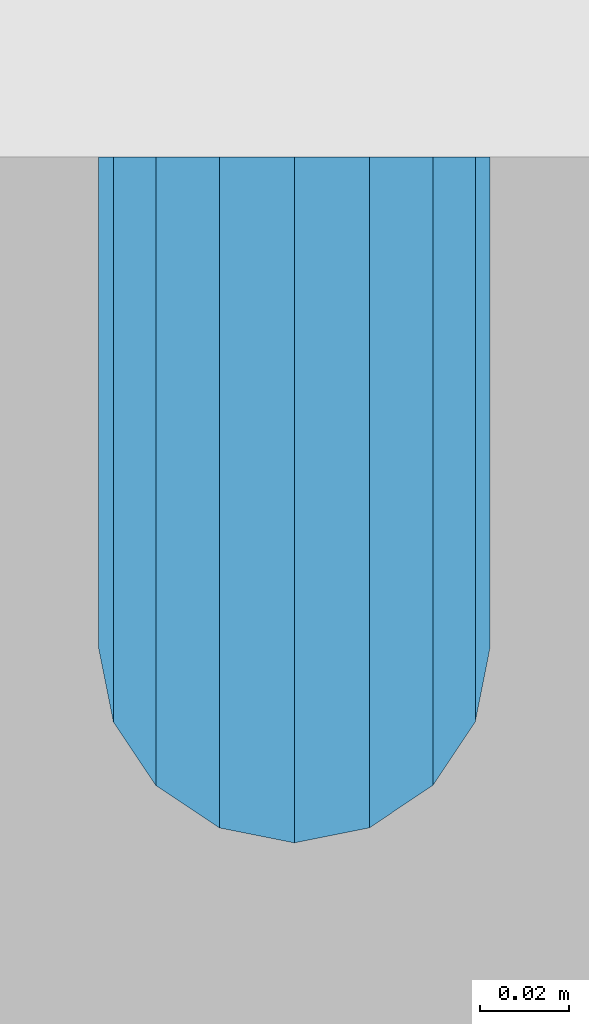
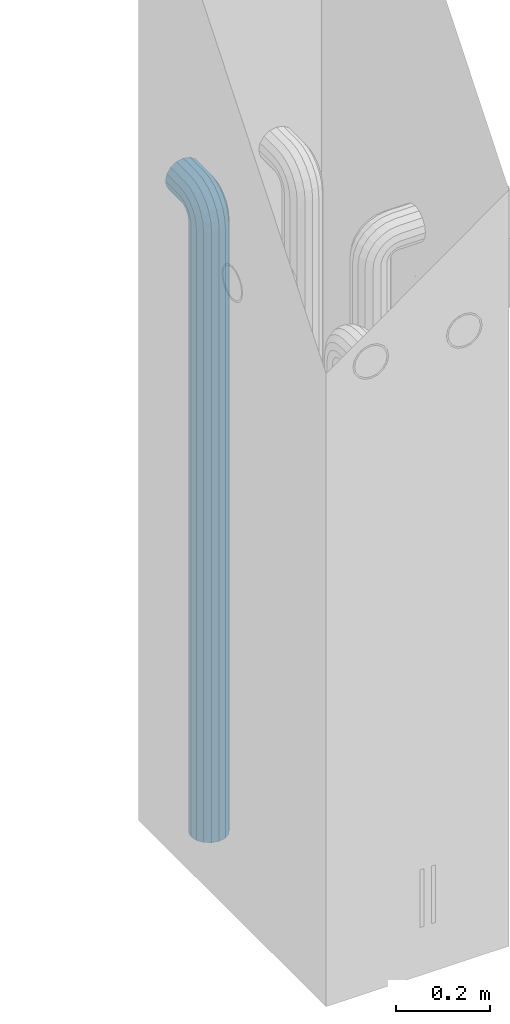
# One storey, part 3 of 41: 1 beam, 2 elements without a shape of their own.
"""IFC2X3 building model written with IfcOpenShell, lengths in millimetres."""

from ifc_helpers import new_model, si_unit, frame, origin_with_axes, place, context, subcontext, project, spatial, faceted_brep, material, type_object, element, aggregate, save


model = new_model("IFC2X3")

# Units and contexts
model_context = context("Model", 3, precision=1e-05, world=origin_with_axes())
body_context = subcontext(model_context, "Body", "Model", "MODEL_VIEW")
ifc_project = project(units=[si_unit("LENGTHUNIT", "METRE", prefix="MILLI"), si_unit("AREAUNIT", "SQUARE_METRE"), si_unit("VOLUMEUNIT", "CUBIC_METRE"), si_unit("MASSUNIT", "GRAM", prefix="KILO"), si_unit("TIMEUNIT", "SECOND"), si_unit("PLANEANGLEUNIT", "RADIAN"), si_unit("SOLIDANGLEUNIT", "STERADIAN"), si_unit("THERMODYNAMICTEMPERATUREUNIT", "DEGREE_CELSIUS"), si_unit("LUMINOUSINTENSITYUNIT", "LUMEN")], contexts=[model_context])

# Site, building, storey
site_placement = place(None, frame((-177556.685383467, -198018.589999756, 1290.0), z_axis=(0.0, 0.0, 1.0), x_axis=(0.788225611989142, -0.615386370180835, 0.0)))
site = spatial("IfcSite", under=ifc_project, at=site_placement, CompositionType="ELEMENT")
building_placement = place(site_placement, origin_with_axes())
building = spatial("IfcBuilding", under=site, at=building_placement, Name="Undefined", CompositionType="ELEMENT")
storey_placement = place(building_placement, origin_with_axes())
storey = spatial("IfcBuildingStorey", under=building, at=storey_placement, Name="Undefined", CompositionType="ELEMENT", Elevation=0.0)

# Assemblies, beam
assembly_1_placement = place(storey_placement, origin_with_axes())
assembly_1 = element("IfcElementAssembly", 1, at=assembly_1_placement, inside=storey, AssemblyPlace="NOTDEFINED", PredefinedType="REINFORCEMENT_UNIT")
assembly_2_placement = place(assembly_1_placement, origin_with_axes())
assembly_2 = element("IfcElementAssembly", 2, at=assembly_2_placement, AssemblyPlace="NOTDEFINED", PredefinedType="RIGID_FRAME")
aggregate(assembly_1, [assembly_2])
ifc_material = material(Name="STEEL/NEG_BETON")
beam_type = type_object("IfcBeamType", PredefinedType="NOTDEFINED")
beam_placement = place(assembly_2_placement, frame((17827.6776781408, 265507.104402164, -1290.0), z_axis=(0.615386370178831, -0.788225611990706, 0.0), x_axis=(0.0, 0.0, 1.0)))
beam = element("IfcBeam", 3, at=beam_placement, type_object=beam_type, material=ifc_material, context=body_context, shape_type="Brep", body=[
    faceted_brep([(0.0, -43.999999753345, 2.88331648334861e-07), (0.0, -40.6506991838105, -16.8380707357428), (1590.0, -40.6506991838105, -16.8380707357428), (1589.99999999999, -43.999999753345, 2.88331648334861e-07), (0.0, -31.1126981254783, -31.1126980838017), (1590.0, -31.1126981254783, -31.1126980838017), (0.0, -16.8380707773322, -40.6506991419883), (1590.0, -16.8380707773322, -40.6506991419883), (0.0, 2.46742274612188e-07, -43.9999997114064), (1590.0, 2.46742274612188e-07, -43.9999997114064), (0.0, 16.8380712707876, -40.6506991418137), (1590.0, 16.8380712707876, -40.6506991418137), (0.0, 31.1126986189047, -31.1126980834524), (1590.0, 31.1126986189047, -31.1126980834524), (0.0, 40.6506996771204, -16.8380707352771), (1590.0, 40.6506996771204, -16.8380707352771), (0.0, 44.0000002465677, 2.88768205791712e-07), (1590.0, 44.0000002465677, 2.88768205791712e-07), (0.0, 40.6506996770622, 16.8380713128427), (1590.0, 40.6506996770622, 16.8380713128427), (0.0, 31.1126986187301, 31.1126986609306), (1590.0, 31.1126986187301, 31.1126986609306), (0.0, 16.8380712705839, 40.6506997191464), (1590.0, 16.8380712705839, 40.6506997191464), (0.0, 2.46509443968534e-07, 44.0000002885354), (1590.0, 2.46509443968534e-07, 44.0000002885354), (0.0, -16.8380707775359, 40.6506997189426), (1590.0, -16.8380707775359, 40.6506997189426), (0.0, -31.1126981256821, 31.1126986605814), (1590.0, -31.1126981256821, 31.1126986605814), (0.0, -40.6506991838978, 16.838071312377), (1590.0, -40.6506991838978, 16.838071312377), (4.47878846898675e-07, -40.0000000634464, 0.0), (4.47878846898675e-07, -36.9551813638827, 15.3073372946019), (1590.0, -36.9551810538396, 15.3073375829845), (1589.99999999999, -39.999999753345, 2.88360752165318e-07), (4.47937054559588e-07, -28.2842713108694, 28.284271247463), (1590.0, -28.2842710008845, 28.2842715359002), (4.4800981413573e-07, -15.3073373580119, 36.9551813004509), (1590.0, -15.3073370480561, 36.9551815889135), (4.48068021796644e-07, -6.34463503956795e-08, 40.0), (1590.0, 2.46538547798991e-07, 40.0000002885645), (4.48140781372786e-07, 15.3073372311774, 36.9551813004509), (1590.0, 15.3073375411332, 36.9551815890882), (4.48213540948927e-07, 28.2842711840058, 28.284271247463), (1590.0, 28.2842714939907, 28.2842715361621), (4.48271748609841e-07, 36.95518123699, 15.3073372946019), (1590.0, 36.9551815469749, 15.3073375833046), (4.48286300525069e-07, 39.9999999365536, 0.0), (1590.0, 40.0000002465677, 2.88768205791712e-07), (4.48271748609841e-07, 36.95518123699, -15.3073372946019), (1590.0, 36.9551815470913, -15.3073370058555), (4.48213540948927e-07, 28.2842711840058, -28.284271247463), (1590.0, 28.2842714941071, -28.2842709587712), (4.48140781372786e-07, 15.3073372311774, -36.9551813004509), (1590.0, 15.3073375413369, -36.9551810117846), (4.48068021796644e-07, -6.34463503956795e-08, -40.0), (1590.0, 2.46742274612188e-07, -39.9999997114064), (4.4800981413573e-07, -15.3073373580119, -36.9551813004509), (1590.0, -15.3073370479106, -36.9551810119592), (4.47937054559588e-07, -28.2842713108694, -28.284271247463), (1590.0, -28.284271000739, -28.2842709590332), (4.47878846898675e-07, -36.9551813638827, -15.3073372946019), (1590.0, -36.9551810537523, -15.3073370062048), (1602.94095225512, -43.9999997526465, -1.70370839745738), (1607.29896571893, -40.6506991831702, 14.560619269585), (1610.99351113838, -31.1126981249254, 28.3488504858688), (1613.46212746447, -16.8380707768374, 37.5618520393036), (1614.32899023963, 2.47237039729953e-07, 40.7970279594592), (1613.46212746447, 16.8380712712533, 37.5618520394491), (1610.99351113838, 31.1126986194577, 28.3488504861598), (1607.29896571893, 40.6506996777607, 14.5606192699925), (1602.94095225512, 44.0000002472952, -1.70370839699171), (1598.5829387913, 40.650699677848, -17.9680360640341), (1594.88839337186, 31.1126986196032, -31.7562672803178), (1592.41977704577, 16.8380712714861, -40.9692688337527), (1591.55291427061, 2.4744076654315e-07, -44.2044447539374), (1592.41977704577, -16.8380707766337, -40.9692688339564), (1594.88839337186, -31.1126981247508, -31.7562672806089), (1598.5829387913, -40.6506991830829, -17.9680360644415), (1613.29371405922, 2.47237039729953e-07, 36.9333246542956), (1612.50565699089, -15.3073370473576, 33.992255635967), (1610.26146033081, -28.284271000186, 25.6167996783042), (1606.90278267677, -36.9551810531411, 13.0820440271636), (1602.94095225512, -39.9999997526465, -1.70370839745738), (1598.97912183347, -36.9551810530538, -16.4894608219911), (1595.62044417943, -28.2842710000114, -29.0242164730153), (1593.37624751934, -15.3073370471539, -37.3996724305616), (1592.58819045102, 2.47411662712693e-07, -40.3407414487447), (1593.37624751934, 15.3073375420063, -37.3996724304452), (1595.62044417943, 28.2842714948347, -29.0242164727533), (1598.97912183347, 36.9551815478189, -16.4894608215836), (1602.94095225512, 40.0000002472952, -1.70370839699171), (1606.90278267677, 36.9551815477316, 13.082044027542), (1610.26146033081, 28.2842714946892, 25.6167996785662), (1612.50565699089, 15.3073375418317, 33.9922556361125), (1630.55634918609, -31.1126981248963, 20.2456576479599), (1635.32534971524, -16.8380707767792, 28.5058088658843), (1623.41903551202, -40.6506991831702, 7.88346773487865), (1614.99999999999, -43.9999997526465, -6.69872952270089), (1606.58096448796, -40.6506991830829, -21.2809267801931), (1599.44365081389, -31.1126981247799, -33.6431166932161), (1594.67465028474, -16.8380707766337, -41.9032679109368), (1592.99999999999, 2.4744076654315e-07, -44.8038472889457), (1594.67465028474, 16.8380712714861, -41.9032679107622), (1599.44365081389, 31.1126986195741, -33.6431166929251), (1606.58096448796, 40.650699677848, -21.2809267798148), (1614.99999999999, 44.0000002472952, -6.69872952226433), (1623.41903551202, 40.6506996777898, 7.88346773531521), (1630.55634918609, 31.1126986194577, 20.24565764828), (1635.32534971524, 16.8380712713115, 28.5058088660007), (1636.99999999999, 2.4726614356041e-07, 31.4063882440387), (1633.47759065022, 15.3073375418608, 25.3053962852573), (1634.99999999999, 2.4726614356041e-07, 27.9422866288805), (1629.14213562372, 28.2842714947183, 17.7961679055006), (1622.65366864729, 36.9551815477607, 6.55781343916897), (1614.99999999999, 40.0000002473244, -6.69872952226433), (1607.34633135269, 36.9551815477898, -19.9552724836976), (1600.85786437626, 28.2842714948347, -31.1936269501166), (1596.52240934976, 15.3073375420354, -38.7028553300188), (1594.99999999999, 2.47411662712693e-07, -41.3397456738458), (1596.52240934976, -15.3073370471539, -38.7028553301352), (1600.85786437626, -28.2842710000696, -31.1936269504367), (1607.34633135269, -36.9551810530538, -19.9552724840469), (1614.99999999999, -39.9999997526465, -6.69872952267178), (1622.65366864729, -36.955181053112, 6.55781343879062), (1629.14213562372, -28.2842710001278, 17.7961679052387), (1633.47759065022, -15.3073370472994, 25.3053962851118), (1647.35533905931, -31.1126981248963, 7.35533934747218), (1654.09972428659, -16.8380707767792, 14.0997245748003), (1637.26165326253, -40.6506991831411, -2.73834644936142), (1625.35533905931, -43.9999997526174, -14.644660652586), (1613.4490248561, -40.650699183112, -26.5509748557815), (1603.35533905931, -31.1126981247508, -36.6446606524696), (1596.61095383203, -16.8380707766046, -43.3890458796814), (1594.24264068711, 2.4744076654315e-07, -45.7573590245447), (1596.61095383203, 16.8380712714861, -43.3890458795358), (1603.35533905931, 31.1126986196032, -36.6446606521786), (1613.4490248561, 40.6506996778771, -26.550974855345), (1625.35533905931, 44.0000002473244, -14.6446606521204), (1637.26165326253, 40.6506996778189, -2.73834644892486), (1647.35533905931, 31.1126986194868, 7.35533934779232), (1654.09972428659, 16.8380712713406, 14.0997245750041), (1656.46803743151, 2.47295247390866e-07, 16.4680377198383), (1651.48659835683, 15.3073375418899, 11.4865986451914), (1653.63961030677, 2.47295247390866e-07, 13.6396105950989), (1645.35533905931, 28.2842714947474, 5.35533934776322), (1636.17926106223, 36.9551815477607, -3.82073864925769), (1625.35533905931, 40.0000002473244, -14.6446606521204), (1614.53141705639, 36.9551815478189, -25.4685826550995), (1605.35533905931, 28.2842714948638, -34.6446606522077), (1599.22407976179, 15.3073375420063, -40.7759199497814), (1597.07106781185, 2.4744076654315e-07, -42.9289318997762), (1599.22407976179, -15.3073370471539, -40.7759199499269), (1605.35533905931, -28.2842710000405, -34.6446606524696), (1614.53141705639, -36.9551810530247, -25.4685826554487), (1625.35533905931, -39.9999997526174, -14.644660652586), (1636.17926106223, -36.9551810530829, -3.82073864963604), (1645.35533905931, -28.2842710001278, 5.35533934750129), (1651.48659835683, -15.3073370472994, 11.486598645075), (1660.24565735981, -31.1126981248381, -9.44365052573266), (1668.50580857761, -16.838070776721, -4.67464999653748), (1647.88346744676, -40.6506991830829, -16.5809641998203), (1633.3012701892, -43.9999997525592, -24.9999997119012), (1618.71907293164, -40.6506991830538, -33.4190352238948), (1606.35688301859, -31.1126981247508, -40.5563488978951), (1598.09673180079, -16.8380707766337, -45.3253494270029), (1595.19615242269, 2.47469870373607e-07, -46.9999997116392), (1598.09673180079, 16.8380712714861, -45.3253494267992), (1606.35688301859, 31.1126986196032, -40.556348897604), (1618.71907293164, 40.6506996778771, -33.4190352235164), (1633.3012701892, 44.0000002473535, -24.9999997114355), (1647.88346744676, 40.650699677848, -16.580964199442), (1660.24565735981, 31.1126986195159, -9.44365052544163), (1668.50580857761, 16.8380712713988, -4.67464999633376), (1671.40638795571, 2.47324351221323e-07, -2.99999971169746), (1665.30539599684, 15.307337541919, -6.52240906140651), (1667.94228634057, 2.47324351221323e-07, -4.99999971172656), (1657.79616761703, 28.2842714948056, -10.8578640878259), (1646.55781315062, 36.9551815477898, -17.3463310641819), (1633.3012701892, 40.0000002473826, -24.9999997114355), (1620.04472722778, 36.955181547848, -32.6536683587765), (1608.80637276137, 28.2842714948638, -39.1421353352489), (1601.29714438156, 15.3073375420063, -43.4775903618138), (1598.66025403783, 2.47469870373607e-07, -44.9999997116392), (1601.29714438156, -15.3073370471539, -43.4775903619302), (1608.80637276137, -28.2842710000114, -39.1421353355108), (1620.04472722778, -36.9551810530247, -32.6536683591548), (1633.3012701892, -39.9999997525883, -24.9999997119012), (1646.55781315062, -36.9551810530538, -17.3463310645602), (1657.79616761703, -28.2842710000987, -10.8578640880878), (1665.30539599684, -15.3073370472412, -6.52240906155203), (1668.34885019768, -31.1126981247799, -29.0064885734755), (1677.56185175105, -16.8380707766628, -26.5378722472815), (1654.56061898146, -40.6506991830538, -32.7010339929548), (1638.29629131443, -43.9999997525592, -37.0590474567725), (1622.0319636474, -40.6506991830538, -41.4170609205903), (1608.24373243118, -31.1126981247508, -45.111606339924), (1599.03073087781, -16.8380707766046, -47.5802226659725), (1595.79555495772, 2.47469870373607e-07, -48.447085441032), (1599.03073087781, 16.8380712715152, -47.5802226657979), (1608.24373243118, 31.1126986196032, -45.1116063396621), (1622.0319636474, 40.6506996779062, -41.4170609201537), (1638.29629131443, 44.0000002474117, -37.059047456336), (1654.56061898146, 40.6506996778771, -32.7010339925182), (1668.34885019768, 31.112698619545, -29.0064885731554), (1677.56185175105, 16.8380712714279, -26.537872247136), (1680.79702767114, 2.47382558882236e-07, -25.6710094720474), (1673.99225534772, 15.3073375420063, -27.494342720689), (1676.93332436598, 2.47382558882236e-07, -26.7062856524717), (1665.61679939011, 28.2842714948056, -29.738539380749), (1653.082043739, 36.9551815478189, -33.0972170347231), (1638.29629131443, 40.0000002473826, -37.059047456336), (1623.51053888986, 36.955181547848, -41.0208778779779), (1610.97578323875, 28.2842714948929, -44.3795555320976), (1602.60032728114, 15.3073375420354, -46.6237521922449), (1599.65925826287, 2.4744076654315e-07, -47.4118092606659), (1602.60032728114, -15.3073370471539, -46.6237521923613), (1610.97578323875, -28.2842710000114, -44.3795555323595), (1623.51053888986, -36.9551810529956, -41.0208778783854), (1638.29629131443, -39.9999997525592, -37.0590474567725), (1653.082043739, -36.9551810529956, -33.0972170350724), (1665.61679939011, -28.2842710000405, -29.73853938104), (1673.99225534772, -15.3073370472121, -27.4943427208927), (1608.88730162777, -31.1126981247216, -49.9999997117848), (1623.16192897591, -40.6506991830247, -49.9999997118721), (1599.34930056949, -16.8380707766046, -49.9999997117557), (1595.99999999998, 2.47469870373607e-07, -49.9999997116684), (1599.34930056949, 16.8380712715152, -49.9999997115519), (1608.88730162777, 31.1126986196323, -49.9999997115228), (1623.16192897591, 40.6506996779353, -49.9999997114355), (1639.99999999997, 44.0000002473826, -49.9999997114646), (1656.83807102403, 40.6506996779353, -49.9999997114355), (1671.11269837217, 31.1126986196323, -49.9999997115228), (1680.65069943045, 16.8380712715152, -49.9999997115519), (1683.99999999996, 2.47469870373607e-07, -49.9999997116684), (1680.65069943045, -16.8380707766046, -49.9999997117557), (1671.11269837217, -31.1126981247216, -49.9999997117848), (1656.83807102403, -40.6506991830247, -49.9999997118721), (1640.0, -43.999999752501, -49.9999997118721), (1676.95518130041, 15.3073375420354, -49.9999997116101), (1679.99999999996, 2.47469870373607e-07, -49.9999997116684), (1668.28427124742, 28.2842714948929, -49.9999997114937), (1655.30733729457, 36.9551815478771, -49.9999997114937), (1639.99999999997, 40.0000002474117, -49.9999997114937), (1624.69266270537, 36.9551815478771, -49.9999997114937), (1611.71572875252, 28.2842714948929, -49.9999997114937), (1603.04481869953, 15.3073375420354, -49.9999997116101), (1599.99999999998, 2.47469870373607e-07, -49.9999997116684), (1603.04481869953, -15.3073370471539, -49.9999997117266), (1611.71572875252, -28.2842710000114, -49.9999997118139), (1624.69266270537, -36.9551810529665, -49.9999997118139), (1640.0, -39.9999997525301, -49.999999711843), (1655.30733729457, -36.9551810529665, -49.999999711843), (1668.28427124742, -28.2842710000114, -49.9999997118139), (1676.95518130041, -15.3073370471247, -49.9999997117266), (1623.16192897594, -40.6506991828792, -109.999999711843), (1640.0, -43.9999997523555, -109.999999711843), (1608.88730162779, -31.1126981245761, -109.999999711785), (1599.3493005695, -16.8380707764591, -109.999999711727), (1596.0, 2.4761538952589e-07, -109.999999711639), (1599.3493005695, 16.8380712716607, -109.999999711552), (1608.88730162779, 31.1126986197778, -109.999999711494), (1623.16192897594, 40.6506996780809, -109.999999711406), (1640.0, 44.0000002475572, -109.999999711436), (1656.83807102406, 40.6506996780809, -109.999999711406), (1671.11269837221, 31.1126986197778, -109.999999711494), (1680.6506994305, 16.8380712716607, -109.999999711552), (1684.0, 2.4761538952589e-07, -109.999999711639), (1680.6506994305, -16.8380707764591, -109.999999711727), (1671.11269837221, -31.1126981245761, -109.999999711785), (1656.83807102406, -40.6506991828792, -109.999999711843), (1655.3073372946, -36.9551810527919, -109.999999711785), (1640.0, -39.9999997523846, -109.999999711843), (1668.28427124746, -28.2842709998658, -109.999999711785), (1676.95518130045, -15.3073370469792, -109.999999711727), (1680.0, 2.4761538952589e-07, -109.999999711639), (1676.95518130045, 15.3073375421809, -109.999999711581), (1668.28427124746, 28.2842714950675, -109.999999711465), (1655.3073372946, 36.9551815479936, -109.999999711465), (1640.0, 40.0000002475572, -109.999999711465), (1624.6926627054, 36.9551815479936, -109.999999711465), (1611.71572875254, 28.2842714950675, -109.999999711465), (1603.04481869955, 15.3073375421809, -109.999999711581), (1600.0, 2.4761538952589e-07, -109.999999711639), (1603.04481869955, -15.3073370469792, -109.999999711727), (1611.71572875254, -28.2842709998658, -109.999999711785), (1624.6926627054, -36.9551810527919, -109.999999711785)], [[[0, 1, 2, 3]], [[1, 4, 5, 2]], [[4, 6, 7, 5]], [[6, 8, 9, 7]], [[8, 10, 11, 9]], [[10, 12, 13, 11]], [[12, 14, 15, 13]], [[14, 16, 17, 15]], [[16, 18, 19, 17]], [[18, 20, 21, 19]], [[20, 22, 23, 21]], [[22, 24, 25, 23]], [[24, 26, 27, 25]], [[26, 28, 29, 27]], [[28, 30, 31, 29]], [[30, 0, 3, 31]], [[32, 33, 34, 35]], [[33, 36, 37, 34]], [[36, 38, 39, 37]], [[38, 40, 41, 39]], [[40, 42, 43, 41]], [[42, 44, 45, 43]], [[44, 46, 47, 45]], [[46, 48, 49, 47]], [[48, 50, 51, 49]], [[50, 52, 53, 51]], [[52, 54, 55, 53]], [[54, 56, 57, 55]], [[56, 58, 59, 57]], [[58, 60, 61, 59]], [[60, 62, 63, 61]], [[62, 32, 35, 63]], [[30, 28, 26, 24, 22, 20, 18, 16, 14, 12, 10, 8, 6, 4, 1, 0], [62, 60, 58, 56, 54, 52, 50, 48, 46, 44, 42, 40, 38, 36, 33, 32]], [[31, 3, 64, 65]], [[29, 31, 65, 66]], [[27, 29, 66, 67]], [[25, 27, 67, 68]], [[23, 25, 68, 69]], [[21, 23, 69, 70]], [[19, 21, 70, 71]], [[17, 19, 71, 72]], [[15, 17, 72, 73]], [[13, 15, 73, 74]], [[11, 13, 74, 75]], [[9, 11, 75, 76]], [[7, 9, 76, 77]], [[5, 7, 77, 78]], [[2, 5, 78, 79]], [[3, 2, 79, 64]], [[39, 41, 80, 81]], [[37, 39, 81, 82]], [[34, 37, 82, 83]], [[35, 34, 83, 84]], [[63, 35, 84, 85]], [[61, 63, 85, 86]], [[59, 61, 86, 87]], [[57, 59, 87, 88]], [[55, 57, 88, 89]], [[53, 55, 89, 90]], [[51, 53, 90, 91]], [[49, 51, 91, 92]], [[47, 49, 92, 93]], [[45, 47, 93, 94]], [[43, 45, 94, 95]], [[41, 43, 95, 80]], [[66, 96, 97, 67]], [[65, 98, 96, 66]], [[64, 99, 98, 65]], [[79, 100, 99, 64]], [[78, 101, 100, 79]], [[77, 102, 101, 78]], [[76, 103, 102, 77]], [[75, 104, 103, 76]], [[74, 105, 104, 75]], [[73, 106, 105, 74]], [[72, 107, 106, 73]], [[71, 108, 107, 72]], [[70, 109, 108, 71]], [[69, 110, 109, 70]], [[68, 111, 110, 69]], [[67, 97, 111, 68]], [[95, 112, 113, 80]], [[94, 114, 112, 95]], [[93, 115, 114, 94]], [[92, 116, 115, 93]], [[91, 117, 116, 92]], [[90, 118, 117, 91]], [[89, 119, 118, 90]], [[88, 120, 119, 89]], [[87, 121, 120, 88]], [[86, 122, 121, 87]], [[85, 123, 122, 86]], [[84, 124, 123, 85]], [[83, 125, 124, 84]], [[82, 126, 125, 83]], [[81, 127, 126, 82]], [[80, 113, 127, 81]], [[96, 128, 129, 97]], [[98, 130, 128, 96]], [[99, 131, 130, 98]], [[100, 132, 131, 99]], [[101, 133, 132, 100]], [[102, 134, 133, 101]], [[103, 135, 134, 102]], [[104, 136, 135, 103]], [[105, 137, 136, 104]], [[106, 138, 137, 105]], [[107, 139, 138, 106]], [[108, 140, 139, 107]], [[109, 141, 140, 108]], [[110, 142, 141, 109]], [[111, 143, 142, 110]], [[97, 129, 143, 111]], [[112, 144, 145, 113]], [[114, 146, 144, 112]], [[115, 147, 146, 114]], [[116, 148, 147, 115]], [[117, 149, 148, 116]], [[118, 150, 149, 117]], [[119, 151, 150, 118]], [[120, 152, 151, 119]], [[121, 153, 152, 120]], [[122, 154, 153, 121]], [[123, 155, 154, 122]], [[124, 156, 155, 123]], [[125, 157, 156, 124]], [[126, 158, 157, 125]], [[127, 159, 158, 126]], [[113, 145, 159, 127]], [[128, 160, 161, 129]], [[130, 162, 160, 128]], [[131, 163, 162, 130]], [[132, 164, 163, 131]], [[133, 165, 164, 132]], [[134, 166, 165, 133]], [[135, 167, 166, 134]], [[136, 168, 167, 135]], [[137, 169, 168, 136]], [[138, 170, 169, 137]], [[139, 171, 170, 138]], [[140, 172, 171, 139]], [[141, 173, 172, 140]], [[142, 174, 173, 141]], [[143, 175, 174, 142]], [[129, 161, 175, 143]], [[144, 176, 177, 145]], [[146, 178, 176, 144]], [[147, 179, 178, 146]], [[148, 180, 179, 147]], [[149, 181, 180, 148]], [[150, 182, 181, 149]], [[151, 183, 182, 150]], [[152, 184, 183, 151]], [[153, 185, 184, 152]], [[154, 186, 185, 153]], [[155, 187, 186, 154]], [[156, 188, 187, 155]], [[157, 189, 188, 156]], [[158, 190, 189, 157]], [[159, 191, 190, 158]], [[145, 177, 191, 159]], [[160, 192, 193, 161]], [[162, 194, 192, 160]], [[163, 195, 194, 162]], [[164, 196, 195, 163]], [[165, 197, 196, 164]], [[166, 198, 197, 165]], [[167, 199, 198, 166]], [[168, 200, 199, 167]], [[169, 201, 200, 168]], [[170, 202, 201, 169]], [[171, 203, 202, 170]], [[172, 204, 203, 171]], [[173, 205, 204, 172]], [[174, 206, 205, 173]], [[175, 207, 206, 174]], [[161, 193, 207, 175]], [[176, 208, 209, 177]], [[178, 210, 208, 176]], [[179, 211, 210, 178]], [[180, 212, 211, 179]], [[181, 213, 212, 180]], [[182, 214, 213, 181]], [[183, 215, 214, 182]], [[184, 216, 215, 183]], [[185, 217, 216, 184]], [[186, 218, 217, 185]], [[187, 219, 218, 186]], [[188, 220, 219, 187]], [[189, 221, 220, 188]], [[190, 222, 221, 189]], [[191, 223, 222, 190]], [[177, 209, 223, 191]], [[197, 224, 225, 196]], [[198, 226, 224, 197]], [[199, 227, 226, 198]], [[200, 228, 227, 199]], [[201, 229, 228, 200]], [[202, 230, 229, 201]], [[203, 231, 230, 202]], [[204, 232, 231, 203]], [[205, 233, 232, 204]], [[206, 234, 233, 205]], [[207, 235, 234, 206]], [[193, 236, 235, 207]], [[192, 237, 236, 193]], [[194, 238, 237, 192]], [[195, 239, 238, 194]], [[196, 225, 239, 195]], [[208, 240, 241, 209]], [[210, 242, 240, 208]], [[211, 243, 242, 210]], [[212, 244, 243, 211]], [[213, 245, 244, 212]], [[214, 246, 245, 213]], [[215, 247, 246, 214]], [[216, 248, 247, 215]], [[217, 249, 248, 216]], [[218, 250, 249, 217]], [[219, 251, 250, 218]], [[220, 252, 251, 219]], [[221, 253, 252, 220]], [[222, 254, 253, 221]], [[223, 255, 254, 222]], [[209, 241, 255, 223]], [[239, 225, 256, 257]], [[225, 224, 258, 256]], [[224, 226, 259, 258]], [[226, 227, 260, 259]], [[227, 228, 261, 260]], [[228, 229, 262, 261]], [[229, 230, 263, 262]], [[230, 231, 264, 263]], [[231, 232, 265, 264]], [[232, 233, 266, 265]], [[233, 234, 267, 266]], [[234, 235, 268, 267]], [[235, 236, 269, 268]], [[236, 237, 270, 269]], [[237, 238, 271, 270]], [[238, 239, 257, 271]], [[252, 253, 272, 273]], [[253, 254, 274, 272]], [[254, 255, 275, 274]], [[255, 241, 276, 275]], [[241, 240, 277, 276]], [[240, 242, 278, 277]], [[242, 243, 279, 278]], [[243, 244, 280, 279]], [[244, 245, 281, 280]], [[245, 246, 282, 281]], [[246, 247, 283, 282]], [[247, 248, 284, 283]], [[248, 249, 285, 284]], [[249, 250, 286, 285]], [[250, 251, 287, 286]], [[251, 252, 273, 287]], [[258, 259, 260, 261, 262, 263, 264, 265, 266, 267, 268, 269, 270, 271, 257, 256], [274, 275, 276, 277, 278, 279, 280, 281, 282, 283, 284, 285, 286, 287, 273, 272]]]),
])
aggregate(assembly_2, [beam])

save(model, "model.ifc")
